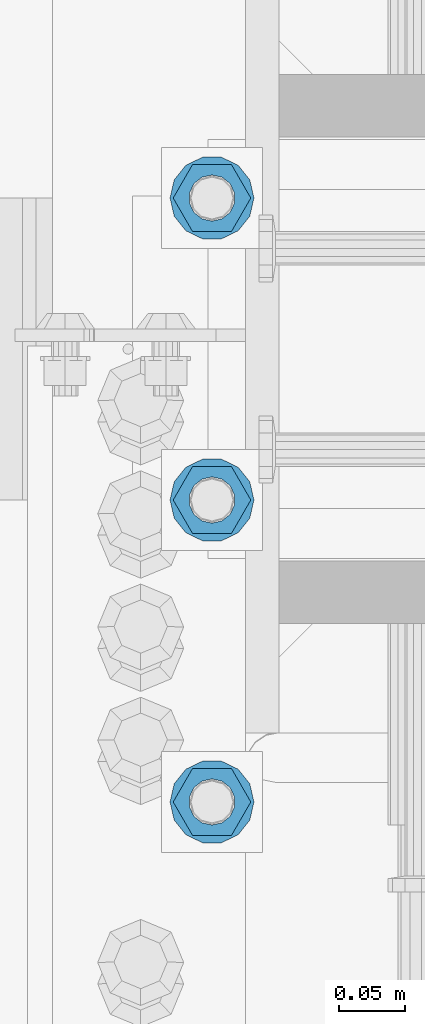
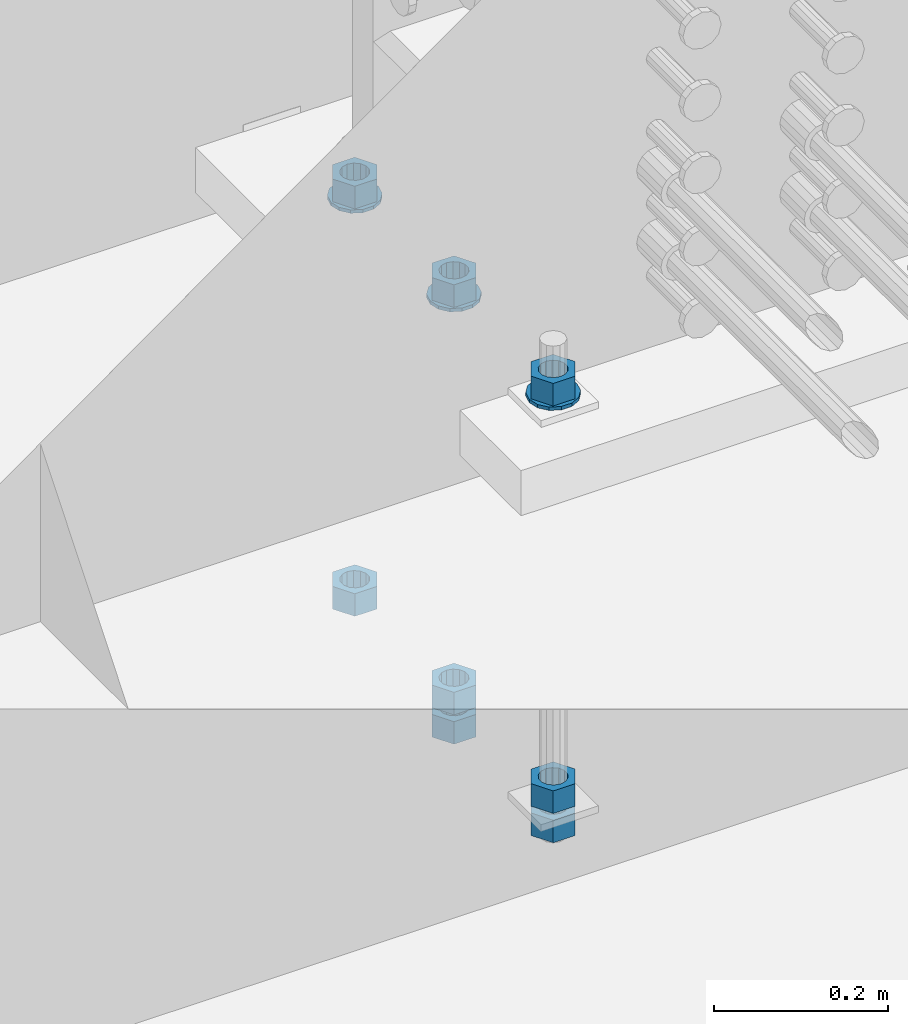
# One storey, part 1013 of 1763: 11 columns, 1 element without a shape of its own.
"""IFC2X3 building model written with IfcOpenShell, lengths in millimetres."""

from ifc_helpers import new_model, si_unit, frame, origin_with_axes, place, context, subcontext, project, spatial, faceted_brep, material, type_object, element, aggregate, save


model = new_model("IFC2X3")

# Units and contexts
model_context = context("Model", 3, precision=1e-05, world=origin_with_axes())
body_context = subcontext(model_context, "Body", "Model", "MODEL_VIEW")
ifc_project = project(units=[si_unit("LENGTHUNIT", "METRE", prefix="MILLI"), si_unit("AREAUNIT", "SQUARE_METRE"), si_unit("VOLUMEUNIT", "CUBIC_METRE"), si_unit("MASSUNIT", "GRAM", prefix="KILO"), si_unit("TIMEUNIT", "SECOND"), si_unit("PLANEANGLEUNIT", "RADIAN"), si_unit("SOLIDANGLEUNIT", "STERADIAN"), si_unit("THERMODYNAMICTEMPERATUREUNIT", "DEGREE_CELSIUS"), si_unit("LUMINOUSINTENSITYUNIT", "LUMEN")], contexts=[model_context])

# Site, building, storey
site_placement = place(None, origin_with_axes())
site = spatial("IfcSite", under=ifc_project, at=site_placement, CompositionType="ELEMENT")
building_placement = place(site_placement, origin_with_axes())
building = spatial("IfcBuilding", under=site, at=building_placement, Name="Undefined", CompositionType="ELEMENT")
storey_placement = place(building_placement, origin_with_axes())
storey = spatial("IfcBuildingStorey", under=building, at=storey_placement, Name="Undefined", CompositionType="ELEMENT", Elevation=0.0)

# Assembly, columns
assembly_placement = place(storey_placement, origin_with_axes())
assembly = element("IfcElementAssembly", 1, at=assembly_placement, inside=storey, Name="TEMPLATE", AssemblyPlace="NOTDEFINED", PredefinedType="RIGID_FRAME")
ifc_material_1 = material(Name="STEEL/A563")
column_type_1 = type_object("IfcColumnType", Name="1-1/4_HEAVY_HEX_NUT", PredefinedType="NOTDEFINED")
column_1_placement = place(assembly_placement, frame((-24281.8372736984, 13347.6999999999, 3957.6375), z_axis=(0.0, -1.0, 0.0), x_axis=(0.0, 0.0, -1.0)))
column_1 = element("IfcColumn", 2, at=column_1_placement, type_object=column_type_1, material=ifc_material_1, Name="NUT", ObjectType="1-1/4_HEAVY_HEX_NUT", context=body_context, shape_type="Brep", body=[
    faceted_brep([(0.0, -29.3700008392334, 0.0), (0.0, -14.6800003051758, -25.4300003051758), (31.75, -14.6800003051758, -25.4300003051758), (31.75, -29.3700008392334, 0.0), (0.0, 14.6800003051758, -25.4300003051758), (31.75, 14.6800003051758, -25.4300003051758), (0.0, 29.3700008392334, 0.0), (31.75, 29.3700008392334, 0.0), (0.0, 14.6800003051758, 25.4300003051758), (31.75, 14.6800003051758, 25.4300003051758), (0.0, -14.6800003051758, 25.4300003051758), (31.75, -14.6800003051758, 25.4300003051758), (0.0, 0.0, 17.4599990844727), (0.0, 7.57560968776022, 15.730915608714), (31.75, 7.57560968775942, 15.7309156087145), (31.75, 0.0, 17.4599990844727), (0.0, 13.6507769681037, 10.8861313696252), (31.75, 13.6507769681048, 10.8861313696314), (0.0, 17.0222404541215, 3.88521530314756), (31.75, 17.02224045412, 3.88521530315316), (0.0, 17.0222404541215, -3.88521530314756), (31.75, 17.02224045412, -3.88521530315332), (0.0, 13.6507769681037, -10.8861313696252), (31.75, 13.6507769681048, -10.8861313696316), (0.0, 7.57560968776022, -15.730915608714), (31.75, 7.57560968775942, -15.7309156087146), (0.0, 0.0, -17.4599990844727), (31.75, 0.0, -17.4599990844727), (0.0, -7.57560968776022, -15.730915608714), (31.75, -7.57560968775942, -15.7309156087145), (0.0, -13.6507769681037, -10.8861313696252), (31.75, -13.6507769681048, -10.8861313696314), (0.0, -17.0222404541215, -3.88521530314756), (31.75, -17.02224045412, -3.88521530315316), (0.0, -17.0222404541215, 3.88521530314756), (31.75, -17.02224045412, 3.88521530315332), (0.0, -13.6507769681037, 10.8861313696252), (31.75, -13.6507769681048, 10.8861313696316), (0.0, -7.57560968776022, 15.730915608714), (31.75, -7.57560968775942, 15.7309156087146)], [[[0, 1, 2, 3]], [[1, 4, 5, 2]], [[4, 6, 7, 5]], [[6, 8, 9, 7]], [[8, 10, 11, 9]], [[10, 0, 3, 11]], [[12, 13, 14, 15]], [[13, 16, 17, 14]], [[16, 18, 19, 17]], [[18, 20, 21, 19]], [[20, 22, 23, 21]], [[22, 24, 25, 23]], [[24, 26, 27, 25]], [[26, 28, 29, 27]], [[28, 30, 31, 29]], [[30, 32, 33, 31]], [[32, 34, 35, 33]], [[34, 36, 37, 35]], [[36, 38, 39, 37]], [[38, 12, 15, 39]], [[5, 7, 9, 11, 3, 2], [17, 19, 21, 23, 25, 27, 29, 31, 33, 35, 37, 39, 15, 14]], [[10, 8, 6, 4, 1, 0], [38, 36, 34, 32, 30, 28, 26, 24, 22, 20, 18, 16, 13, 12]]]),
])
column_2_placement = place(assembly_placement, frame((-24281.8372736984, 13347.6999999999, 3384.55), z_axis=(0.0, -1.0, 0.0), x_axis=(0.0, 0.0, -1.0)))
column_2 = element("IfcColumn", 3, at=column_2_placement, type_object=column_type_1, material=ifc_material_1, Name="NUT", ObjectType="1-1/4_HEAVY_HEX_NUT", context=body_context, shape_type="Brep", body=[
    faceted_brep([(0.0, -29.3700008392334, 0.0), (0.0, -14.6800003051758, -25.4300003051758), (31.75, -14.6800003051758, -25.4300003051758), (31.75, -29.3700008392334, 0.0), (0.0, 14.6800003051758, -25.4300003051758), (31.75, 14.6800003051758, -25.4300003051758), (0.0, 29.3700008392334, 0.0), (31.75, 29.3700008392334, 0.0), (0.0, 14.6800003051758, 25.4300003051758), (31.75, 14.6800003051758, 25.4300003051758), (0.0, -14.6800003051758, 25.4300003051758), (31.75, -14.6800003051758, 25.4300003051758), (0.0, 0.0, 17.4599990844727), (0.0, 7.57560968776022, 15.730915608714), (31.75, 7.57560968775942, 15.7309156087145), (31.75, 0.0, 17.4599990844727), (0.0, 13.6507769681037, 10.8861313696252), (31.75, 13.6507769681048, 10.8861313696314), (0.0, 17.0222404541215, 3.88521530314756), (31.75, 17.02224045412, 3.88521530315316), (0.0, 17.0222404541215, -3.88521530314756), (31.75, 17.02224045412, -3.88521530315332), (0.0, 13.6507769681037, -10.8861313696252), (31.75, 13.6507769681048, -10.8861313696316), (0.0, 7.57560968776022, -15.730915608714), (31.75, 7.57560968775942, -15.7309156087146), (0.0, 0.0, -17.4599990844727), (31.75, 0.0, -17.4599990844727), (0.0, -7.57560968776022, -15.730915608714), (31.75, -7.57560968775942, -15.7309156087145), (0.0, -13.6507769681037, -10.8861313696252), (31.75, -13.6507769681048, -10.8861313696314), (0.0, -17.0222404541215, -3.88521530314756), (31.75, -17.02224045412, -3.88521530315316), (0.0, -17.0222404541215, 3.88521530314756), (31.75, -17.02224045412, 3.88521530315332), (0.0, -13.6507769681037, 10.8861313696252), (31.75, -13.6507769681048, 10.8861313696316), (0.0, -7.57560968776022, 15.730915608714), (31.75, -7.57560968775942, 15.7309156087146)], [[[0, 1, 2, 3]], [[1, 4, 5, 2]], [[4, 6, 7, 5]], [[6, 8, 9, 7]], [[8, 10, 11, 9]], [[10, 0, 3, 11]], [[12, 13, 14, 15]], [[13, 16, 17, 14]], [[16, 18, 19, 17]], [[18, 20, 21, 19]], [[20, 22, 23, 21]], [[22, 24, 25, 23]], [[24, 26, 27, 25]], [[26, 28, 29, 27]], [[28, 30, 31, 29]], [[30, 32, 33, 31]], [[32, 34, 35, 33]], [[34, 36, 37, 35]], [[36, 38, 39, 37]], [[38, 12, 15, 39]], [[5, 7, 9, 11, 3, 2], [17, 19, 21, 23, 25, 27, 29, 31, 33, 35, 37, 39, 15, 14]], [[10, 8, 6, 4, 1, 0], [38, 36, 34, 32, 30, 28, 26, 24, 22, 20, 18, 16, 13, 12]]]),
])
column_3_placement = place(assembly_placement, frame((-24281.8372736984, 13347.6999999999, 3343.275), z_axis=(0.0, -1.0, 0.0), x_axis=(0.0, 0.0, -1.0)))
column_3 = element("IfcColumn", 4, at=column_3_placement, type_object=column_type_1, material=ifc_material_1, Name="NUT", ObjectType="1-1/4_HEAVY_HEX_NUT", context=body_context, shape_type="Brep", body=[
    faceted_brep([(0.0, -29.3700008392334, 0.0), (0.0, -14.6800003051758, -25.4300003051758), (31.75, -14.6800003051758, -25.4300003051758), (31.75, -29.3700008392334, 0.0), (0.0, 14.6800003051758, -25.4300003051758), (31.75, 14.6800003051758, -25.4300003051758), (0.0, 29.3700008392334, 0.0), (31.75, 29.3700008392334, 0.0), (0.0, 14.6800003051758, 25.4300003051758), (31.75, 14.6800003051758, 25.4300003051758), (0.0, -14.6800003051758, 25.4300003051758), (31.75, -14.6800003051758, 25.4300003051758), (0.0, 0.0, 17.4599990844727), (0.0, 7.57560968776022, 15.730915608714), (31.75, 7.57560968775942, 15.7309156087145), (31.75, 0.0, 17.4599990844727), (0.0, 13.6507769681037, 10.8861313696252), (31.75, 13.6507769681048, 10.8861313696314), (0.0, 17.0222404541215, 3.88521530314756), (31.75, 17.02224045412, 3.88521530315316), (0.0, 17.0222404541215, -3.88521530314756), (31.75, 17.02224045412, -3.88521530315332), (0.0, 13.6507769681037, -10.8861313696252), (31.75, 13.6507769681048, -10.8861313696316), (0.0, 7.57560968776022, -15.730915608714), (31.75, 7.57560968775942, -15.7309156087146), (0.0, 0.0, -17.4599990844727), (31.75, 0.0, -17.4599990844727), (0.0, -7.57560968776022, -15.730915608714), (31.75, -7.57560968775942, -15.7309156087145), (0.0, -13.6507769681037, -10.8861313696252), (31.75, -13.6507769681048, -10.8861313696314), (0.0, -17.0222404541215, -3.88521530314756), (31.75, -17.02224045412, -3.88521530315316), (0.0, -17.0222404541215, 3.88521530314756), (31.75, -17.02224045412, 3.88521530315332), (0.0, -13.6507769681037, 10.8861313696252), (31.75, -13.6507769681048, 10.8861313696316), (0.0, -7.57560968776022, 15.730915608714), (31.75, -7.57560968775942, 15.7309156087146)], [[[0, 1, 2, 3]], [[1, 4, 5, 2]], [[4, 6, 7, 5]], [[6, 8, 9, 7]], [[8, 10, 11, 9]], [[10, 0, 3, 11]], [[12, 13, 14, 15]], [[13, 16, 17, 14]], [[16, 18, 19, 17]], [[18, 20, 21, 19]], [[20, 22, 23, 21]], [[22, 24, 25, 23]], [[24, 26, 27, 25]], [[26, 28, 29, 27]], [[28, 30, 31, 29]], [[30, 32, 33, 31]], [[32, 34, 35, 33]], [[34, 36, 37, 35]], [[36, 38, 39, 37]], [[38, 12, 15, 39]], [[5, 7, 9, 11, 3, 2], [17, 19, 21, 23, 25, 27, 29, 31, 33, 35, 37, 39, 15, 14]], [[10, 8, 6, 4, 1, 0], [38, 36, 34, 32, 30, 28, 26, 24, 22, 20, 18, 16, 13, 12]]]),
])
column_4_placement = place(assembly_placement, frame((-24281.8372736984, 13576.2999999999, 3957.6375), z_axis=(0.0, -1.0, 0.0), x_axis=(0.0, 0.0, -1.0)))
column_4 = element("IfcColumn", 5, at=column_4_placement, type_object=column_type_1, material=ifc_material_1, Name="NUT", ObjectType="1-1/4_HEAVY_HEX_NUT", context=body_context, shape_type="Brep", body=[
    faceted_brep([(0.0, -29.3700008392334, 0.0), (0.0, -14.6800003051758, -25.4300003051758), (31.75, -14.6800003051758, -25.4300003051758), (31.75, -29.3700008392334, 0.0), (0.0, 14.6800003051758, -25.4300003051758), (31.75, 14.6800003051758, -25.4300003051758), (0.0, 29.3700008392334, 0.0), (31.75, 29.3700008392334, 0.0), (0.0, 14.6800003051758, 25.4300003051758), (31.75, 14.6800003051758, 25.4300003051758), (0.0, -14.6800003051758, 25.4300003051758), (31.75, -14.6800003051758, 25.4300003051758), (0.0, 0.0, 17.4599990844727), (0.0, 7.57560968776022, 15.730915608714), (31.75, 7.57560968775942, 15.7309156087145), (31.75, 0.0, 17.4599990844727), (0.0, 13.6507769681037, 10.8861313696252), (31.75, 13.6507769681048, 10.8861313696314), (0.0, 17.0222404541215, 3.88521530314756), (31.75, 17.02224045412, 3.88521530315316), (0.0, 17.0222404541215, -3.88521530314756), (31.75, 17.02224045412, -3.88521530315332), (0.0, 13.6507769681037, -10.8861313696252), (31.75, 13.6507769681048, -10.8861313696316), (0.0, 7.57560968776022, -15.730915608714), (31.75, 7.57560968775942, -15.7309156087146), (0.0, 0.0, -17.4599990844727), (31.75, 0.0, -17.4599990844727), (0.0, -7.57560968776022, -15.730915608714), (31.75, -7.57560968775942, -15.7309156087145), (0.0, -13.6507769681037, -10.8861313696252), (31.75, -13.6507769681048, -10.8861313696314), (0.0, -17.0222404541215, -3.88521530314756), (31.75, -17.02224045412, -3.88521530315316), (0.0, -17.0222404541215, 3.88521530314756), (31.75, -17.02224045412, 3.88521530315332), (0.0, -13.6507769681037, 10.8861313696252), (31.75, -13.6507769681048, 10.8861313696316), (0.0, -7.57560968776022, 15.730915608714), (31.75, -7.57560968775942, 15.7309156087146)], [[[0, 1, 2, 3]], [[1, 4, 5, 2]], [[4, 6, 7, 5]], [[6, 8, 9, 7]], [[8, 10, 11, 9]], [[10, 0, 3, 11]], [[12, 13, 14, 15]], [[13, 16, 17, 14]], [[16, 18, 19, 17]], [[18, 20, 21, 19]], [[20, 22, 23, 21]], [[22, 24, 25, 23]], [[24, 26, 27, 25]], [[26, 28, 29, 27]], [[28, 30, 31, 29]], [[30, 32, 33, 31]], [[32, 34, 35, 33]], [[34, 36, 37, 35]], [[36, 38, 39, 37]], [[38, 12, 15, 39]], [[5, 7, 9, 11, 3, 2], [17, 19, 21, 23, 25, 27, 29, 31, 33, 35, 37, 39, 15, 14]], [[10, 8, 6, 4, 1, 0], [38, 36, 34, 32, 30, 28, 26, 24, 22, 20, 18, 16, 13, 12]]]),
])
column_5_placement = place(assembly_placement, frame((-24281.8372736984, 13576.2999999999, 3384.55), z_axis=(0.0, -1.0, 0.0), x_axis=(0.0, 0.0, -1.0)))
column_5 = element("IfcColumn", 6, at=column_5_placement, type_object=column_type_1, material=ifc_material_1, Name="NUT", ObjectType="1-1/4_HEAVY_HEX_NUT", context=body_context, shape_type="Brep", body=[
    faceted_brep([(0.0, -29.3700008392334, 0.0), (0.0, -14.6800003051758, -25.4300003051758), (31.75, -14.6800003051758, -25.4300003051758), (31.75, -29.3700008392334, 0.0), (0.0, 14.6800003051758, -25.4300003051758), (31.75, 14.6800003051758, -25.4300003051758), (0.0, 29.3700008392334, 0.0), (31.75, 29.3700008392334, 0.0), (0.0, 14.6800003051758, 25.4300003051758), (31.75, 14.6800003051758, 25.4300003051758), (0.0, -14.6800003051758, 25.4300003051758), (31.75, -14.6800003051758, 25.4300003051758), (0.0, 0.0, 17.4599990844727), (0.0, 7.57560968776022, 15.730915608714), (31.75, 7.57560968775942, 15.7309156087145), (31.75, 0.0, 17.4599990844727), (0.0, 13.6507769681037, 10.8861313696252), (31.75, 13.6507769681048, 10.8861313696314), (0.0, 17.0222404541215, 3.88521530314756), (31.75, 17.02224045412, 3.88521530315316), (0.0, 17.0222404541215, -3.88521530314756), (31.75, 17.02224045412, -3.88521530315332), (0.0, 13.6507769681037, -10.8861313696252), (31.75, 13.6507769681048, -10.8861313696316), (0.0, 7.57560968776022, -15.730915608714), (31.75, 7.57560968775942, -15.7309156087146), (0.0, 0.0, -17.4599990844727), (31.75, 0.0, -17.4599990844727), (0.0, -7.57560968776022, -15.730915608714), (31.75, -7.57560968775942, -15.7309156087145), (0.0, -13.6507769681037, -10.8861313696252), (31.75, -13.6507769681048, -10.8861313696314), (0.0, -17.0222404541215, -3.88521530314756), (31.75, -17.02224045412, -3.88521530315316), (0.0, -17.0222404541215, 3.88521530314756), (31.75, -17.02224045412, 3.88521530315332), (0.0, -13.6507769681037, 10.8861313696252), (31.75, -13.6507769681048, 10.8861313696316), (0.0, -7.57560968776022, 15.730915608714), (31.75, -7.57560968775942, 15.7309156087146)], [[[0, 1, 2, 3]], [[1, 4, 5, 2]], [[4, 6, 7, 5]], [[6, 8, 9, 7]], [[8, 10, 11, 9]], [[10, 0, 3, 11]], [[12, 13, 14, 15]], [[13, 16, 17, 14]], [[16, 18, 19, 17]], [[18, 20, 21, 19]], [[20, 22, 23, 21]], [[22, 24, 25, 23]], [[24, 26, 27, 25]], [[26, 28, 29, 27]], [[28, 30, 31, 29]], [[30, 32, 33, 31]], [[32, 34, 35, 33]], [[34, 36, 37, 35]], [[36, 38, 39, 37]], [[38, 12, 15, 39]], [[5, 7, 9, 11, 3, 2], [17, 19, 21, 23, 25, 27, 29, 31, 33, 35, 37, 39, 15, 14]], [[10, 8, 6, 4, 1, 0], [38, 36, 34, 32, 30, 28, 26, 24, 22, 20, 18, 16, 13, 12]]]),
])
column_6_placement = place(assembly_placement, frame((-24281.8372736984, 13576.2999999999, 3343.275), z_axis=(0.0, -1.0, 0.0), x_axis=(0.0, 0.0, -1.0)))
column_6 = element("IfcColumn", 7, at=column_6_placement, type_object=column_type_1, material=ifc_material_1, Name="NUT", ObjectType="1-1/4_HEAVY_HEX_NUT", context=body_context, shape_type="Brep", body=[
    faceted_brep([(0.0, -29.3700008392334, 0.0), (0.0, -14.6800003051758, -25.4300003051758), (31.75, -14.6800003051758, -25.4300003051758), (31.75, -29.3700008392334, 0.0), (0.0, 14.6800003051758, -25.4300003051758), (31.75, 14.6800003051758, -25.4300003051758), (0.0, 29.3700008392334, 0.0), (31.75, 29.3700008392334, 0.0), (0.0, 14.6800003051758, 25.4300003051758), (31.75, 14.6800003051758, 25.4300003051758), (0.0, -14.6800003051758, 25.4300003051758), (31.75, -14.6800003051758, 25.4300003051758), (0.0, 0.0, 17.4599990844727), (0.0, 7.57560968776022, 15.730915608714), (31.75, 7.57560968775942, 15.7309156087145), (31.75, 0.0, 17.4599990844727), (0.0, 13.6507769681037, 10.8861313696252), (31.75, 13.6507769681048, 10.8861313696314), (0.0, 17.0222404541215, 3.88521530314756), (31.75, 17.02224045412, 3.88521530315316), (0.0, 17.0222404541215, -3.88521530314756), (31.75, 17.02224045412, -3.88521530315332), (0.0, 13.6507769681037, -10.8861313696252), (31.75, 13.6507769681048, -10.8861313696316), (0.0, 7.57560968776022, -15.730915608714), (31.75, 7.57560968775942, -15.7309156087146), (0.0, 0.0, -17.4599990844727), (31.75, 0.0, -17.4599990844727), (0.0, -7.57560968776022, -15.730915608714), (31.75, -7.57560968775942, -15.7309156087145), (0.0, -13.6507769681037, -10.8861313696252), (31.75, -13.6507769681048, -10.8861313696314), (0.0, -17.0222404541215, -3.88521530314756), (31.75, -17.02224045412, -3.88521530315316), (0.0, -17.0222404541215, 3.88521530314756), (31.75, -17.02224045412, 3.88521530315332), (0.0, -13.6507769681037, 10.8861313696252), (31.75, -13.6507769681048, 10.8861313696316), (0.0, -7.57560968776022, 15.730915608714), (31.75, -7.57560968775942, 15.7309156087146)], [[[0, 1, 2, 3]], [[1, 4, 5, 2]], [[4, 6, 7, 5]], [[6, 8, 9, 7]], [[8, 10, 11, 9]], [[10, 0, 3, 11]], [[12, 13, 14, 15]], [[13, 16, 17, 14]], [[16, 18, 19, 17]], [[18, 20, 21, 19]], [[20, 22, 23, 21]], [[22, 24, 25, 23]], [[24, 26, 27, 25]], [[26, 28, 29, 27]], [[28, 30, 31, 29]], [[30, 32, 33, 31]], [[32, 34, 35, 33]], [[34, 36, 37, 35]], [[36, 38, 39, 37]], [[38, 12, 15, 39]], [[5, 7, 9, 11, 3, 2], [17, 19, 21, 23, 25, 27, 29, 31, 33, 35, 37, 39, 15, 14]], [[10, 8, 6, 4, 1, 0], [38, 36, 34, 32, 30, 28, 26, 24, 22, 20, 18, 16, 13, 12]]]),
])
column_7_placement = place(assembly_placement, frame((-24281.8372736984, 13804.8999999999, 3957.6375), z_axis=(0.0, -1.0, 0.0), x_axis=(0.0, 0.0, -1.0)))
column_7 = element("IfcColumn", 8, at=column_7_placement, type_object=column_type_1, material=ifc_material_1, Name="NUT", ObjectType="1-1/4_HEAVY_HEX_NUT", context=body_context, shape_type="Brep", body=[
    faceted_brep([(0.0, -29.3700008392334, 0.0), (0.0, -14.6800003051758, -25.4300003051758), (31.75, -14.6800003051758, -25.4300003051758), (31.75, -29.3700008392334, 0.0), (0.0, 14.6800003051758, -25.4300003051758), (31.75, 14.6800003051758, -25.4300003051758), (0.0, 29.3700008392334, 0.0), (31.75, 29.3700008392334, 0.0), (0.0, 14.6800003051758, 25.4300003051758), (31.75, 14.6800003051758, 25.4300003051758), (0.0, -14.6800003051758, 25.4300003051758), (31.75, -14.6800003051758, 25.4300003051758), (0.0, 0.0, 17.4599990844727), (0.0, 7.57560968776022, 15.730915608714), (31.75, 7.57560968775942, 15.7309156087145), (31.75, 0.0, 17.4599990844727), (0.0, 13.6507769681037, 10.8861313696252), (31.75, 13.6507769681048, 10.8861313696314), (0.0, 17.0222404541215, 3.88521530314756), (31.75, 17.02224045412, 3.88521530315316), (0.0, 17.0222404541215, -3.88521530314756), (31.75, 17.02224045412, -3.88521530315332), (0.0, 13.6507769681037, -10.8861313696252), (31.75, 13.6507769681048, -10.8861313696316), (0.0, 7.57560968776022, -15.730915608714), (31.75, 7.57560968775942, -15.7309156087146), (0.0, 0.0, -17.4599990844727), (31.75, 0.0, -17.4599990844727), (0.0, -7.57560968776022, -15.730915608714), (31.75, -7.57560968775942, -15.7309156087145), (0.0, -13.6507769681037, -10.8861313696252), (31.75, -13.6507769681048, -10.8861313696314), (0.0, -17.0222404541215, -3.88521530314756), (31.75, -17.02224045412, -3.88521530315316), (0.0, -17.0222404541215, 3.88521530314756), (31.75, -17.02224045412, 3.88521530315332), (0.0, -13.6507769681037, 10.8861313696252), (31.75, -13.6507769681048, 10.8861313696316), (0.0, -7.57560968776022, 15.730915608714), (31.75, -7.57560968775942, 15.7309156087146)], [[[0, 1, 2, 3]], [[1, 4, 5, 2]], [[4, 6, 7, 5]], [[6, 8, 9, 7]], [[8, 10, 11, 9]], [[10, 0, 3, 11]], [[12, 13, 14, 15]], [[13, 16, 17, 14]], [[16, 18, 19, 17]], [[18, 20, 21, 19]], [[20, 22, 23, 21]], [[22, 24, 25, 23]], [[24, 26, 27, 25]], [[26, 28, 29, 27]], [[28, 30, 31, 29]], [[30, 32, 33, 31]], [[32, 34, 35, 33]], [[34, 36, 37, 35]], [[36, 38, 39, 37]], [[38, 12, 15, 39]], [[5, 7, 9, 11, 3, 2], [17, 19, 21, 23, 25, 27, 29, 31, 33, 35, 37, 39, 15, 14]], [[10, 8, 6, 4, 1, 0], [38, 36, 34, 32, 30, 28, 26, 24, 22, 20, 18, 16, 13, 12]]]),
])
column_8_placement = place(assembly_placement, frame((-24281.8372736984, 13804.8999999999, 3384.55), z_axis=(0.0, -1.0, 0.0), x_axis=(0.0, 0.0, -1.0)))
column_8 = element("IfcColumn", 9, at=column_8_placement, type_object=column_type_1, material=ifc_material_1, Name="NUT", ObjectType="1-1/4_HEAVY_HEX_NUT", context=body_context, shape_type="Brep", body=[
    faceted_brep([(0.0, -29.3700008392334, 0.0), (0.0, -14.6800003051758, -25.4300003051758), (31.75, -14.6800003051758, -25.4300003051758), (31.75, -29.3700008392334, 0.0), (0.0, 14.6800003051758, -25.4300003051758), (31.75, 14.6800003051758, -25.4300003051758), (0.0, 29.3700008392334, 0.0), (31.75, 29.3700008392334, 0.0), (0.0, 14.6800003051758, 25.4300003051758), (31.75, 14.6800003051758, 25.4300003051758), (0.0, -14.6800003051758, 25.4300003051758), (31.75, -14.6800003051758, 25.4300003051758), (0.0, 0.0, 17.4599990844727), (0.0, 7.57560968776022, 15.730915608714), (31.75, 7.57560968775942, 15.7309156087145), (31.75, 0.0, 17.4599990844727), (0.0, 13.6507769681037, 10.8861313696252), (31.75, 13.6507769681048, 10.8861313696314), (0.0, 17.0222404541215, 3.88521530314756), (31.75, 17.02224045412, 3.88521530315316), (0.0, 17.0222404541215, -3.88521530314756), (31.75, 17.02224045412, -3.88521530315332), (0.0, 13.6507769681037, -10.8861313696252), (31.75, 13.6507769681048, -10.8861313696316), (0.0, 7.57560968776022, -15.730915608714), (31.75, 7.57560968775942, -15.7309156087146), (0.0, 0.0, -17.4599990844727), (31.75, 0.0, -17.4599990844727), (0.0, -7.57560968776022, -15.730915608714), (31.75, -7.57560968775942, -15.7309156087145), (0.0, -13.6507769681037, -10.8861313696252), (31.75, -13.6507769681048, -10.8861313696314), (0.0, -17.0222404541215, -3.88521530314756), (31.75, -17.02224045412, -3.88521530315316), (0.0, -17.0222404541215, 3.88521530314756), (31.75, -17.02224045412, 3.88521530315332), (0.0, -13.6507769681037, 10.8861313696252), (31.75, -13.6507769681048, 10.8861313696316), (0.0, -7.57560968776022, 15.730915608714), (31.75, -7.57560968775942, 15.7309156087146)], [[[0, 1, 2, 3]], [[1, 4, 5, 2]], [[4, 6, 7, 5]], [[6, 8, 9, 7]], [[8, 10, 11, 9]], [[10, 0, 3, 11]], [[12, 13, 14, 15]], [[13, 16, 17, 14]], [[16, 18, 19, 17]], [[18, 20, 21, 19]], [[20, 22, 23, 21]], [[22, 24, 25, 23]], [[24, 26, 27, 25]], [[26, 28, 29, 27]], [[28, 30, 31, 29]], [[30, 32, 33, 31]], [[32, 34, 35, 33]], [[34, 36, 37, 35]], [[36, 38, 39, 37]], [[38, 12, 15, 39]], [[5, 7, 9, 11, 3, 2], [17, 19, 21, 23, 25, 27, 29, 31, 33, 35, 37, 39, 15, 14]], [[10, 8, 6, 4, 1, 0], [38, 36, 34, 32, 30, 28, 26, 24, 22, 20, 18, 16, 13, 12]]]),
])
ifc_material_2 = material(Name="STEEL/F436")
column_type_2 = type_object("IfcColumnType", Name="1-1/4_WASHER", PredefinedType="NOTDEFINED")
column_9_placement = place(assembly_placement, frame((-24281.8372736984, 13347.6999999999, 3925.8875), z_axis=(0.0, -1.0, 0.0), x_axis=(0.0, 0.0, -1.0)))
column_9 = element("IfcColumn", 10, at=column_9_placement, type_object=column_type_2, material=ifc_material_2, Name="WASHER", ObjectType="1-1/4_WASHER", context=body_context, shape_type="Brep", body=[
    faceted_brep([(-4.54747350886464e-13, -31.7499999999964, 0.0), (0.0, -28.6057615559002, -13.7758087169827), (4.76249999999982, -28.6057615559002, -13.7758087169827), (4.76249999999982, -31.75, 0.0), (0.0, -19.795801209013, -24.8231495683602), (4.76249999999982, -19.795801209013, -24.8231495683602), (0.0, -7.06503965311276, -30.9539612117732), (4.76249999999982, -7.06503965311276, -30.9539612117732), (0.0, 7.06503965311276, -30.9539612117732), (4.76249999999982, 7.06503965311276, -30.9539612117732), (0.0, 19.7958012090166, -24.8231495683602), (4.76249999999982, 19.7958012090166, -24.8231495683602), (0.0, 28.6057615559039, -13.7758087169827), (4.76249999999982, 28.6057615559039, -13.7758087169827), (-5.91171556152403e-12, 31.7499999999891, 0.0), (4.76249999999982, 31.75, 0.0), (0.0, 28.6057615559002, 13.7758087169827), (4.76249999999982, 28.6057615559002, 13.7758087169827), (0.0, 19.795801209013, 24.8231495683602), (4.76249999999982, 19.795801209013, 24.8231495683602), (0.0, 7.06503965311276, 30.9539612117731), (4.76249999999982, 7.06503965311276, 30.9539612117731), (0.0, -7.06503965311276, 30.9539612117731), (4.76249999999982, -7.06503965311276, 30.9539612117731), (0.0, -19.7958012090166, 24.8231495683602), (4.76249999999982, -19.7958012090166, 24.8231495683602), (0.0, -28.6057615559039, 13.7758087169827), (4.76249999999982, -28.6057615559039, 13.7758087169827), (0.0, 0.0, 17.4599990844727), (0.0, 7.57560968776022, 15.730915608714), (4.76249999999982, 7.57560968775942, 15.7309156087145), (4.76249999999982, 0.0, 17.4599990844727), (0.0, 13.6507769681037, 10.8861313696252), (4.76249999999982, 13.6507769681048, 10.8861313696314), (0.0, 17.0222404541215, 3.88521530314756), (4.76249999999982, 17.02224045412, 3.88521530315316), (0.0, 17.0222404541215, -3.88521530314756), (4.76249999999982, 17.02224045412, -3.88521530315332), (0.0, 13.6507769681037, -10.8861313696252), (4.76249999999982, 13.6507769681048, -10.8861313696316), (0.0, 7.57560968776022, -15.730915608714), (4.76249999999982, 7.57560968775942, -15.7309156087146), (0.0, 0.0, -17.4599990844727), (4.76249999999982, 0.0, -17.4599990844727), (0.0, -7.57560968776022, -15.730915608714), (4.76249999999982, -7.57560968775942, -15.7309156087145), (0.0, -13.6507769681037, -10.8861313696252), (4.76249999999982, -13.6507769681048, -10.8861313696314), (0.0, -17.0222404541215, -3.88521530314756), (4.76249999999982, -17.02224045412, -3.88521530315316), (0.0, -17.0222404541215, 3.88521530314756), (4.76249999999982, -17.02224045412, 3.88521530315332), (0.0, -13.6507769681037, 10.8861313696252), (4.76249999999982, -13.6507769681048, 10.8861313696316), (0.0, -7.57560968776022, 15.730915608714), (4.76249999999982, -7.57560968775942, 15.7309156087146)], [[[0, 1, 2, 3]], [[1, 4, 5, 2]], [[4, 6, 7, 5]], [[6, 8, 9, 7]], [[8, 10, 11, 9]], [[10, 12, 13, 11]], [[12, 14, 15, 13]], [[14, 16, 17, 15]], [[16, 18, 19, 17]], [[18, 20, 21, 19]], [[20, 22, 23, 21]], [[22, 24, 25, 23]], [[24, 26, 27, 25]], [[26, 0, 3, 27]], [[28, 29, 30, 31]], [[29, 32, 33, 30]], [[32, 34, 35, 33]], [[34, 36, 37, 35]], [[36, 38, 39, 37]], [[38, 40, 41, 39]], [[40, 42, 43, 41]], [[42, 44, 45, 43]], [[44, 46, 47, 45]], [[46, 48, 49, 47]], [[48, 50, 51, 49]], [[50, 52, 53, 51]], [[52, 54, 55, 53]], [[54, 28, 31, 55]], [[5, 7, 9, 11, 13, 15, 17, 19, 21, 23, 25, 27, 3, 2], [33, 35, 37, 39, 41, 43, 45, 47, 49, 51, 53, 55, 31, 30]], [[26, 24, 22, 20, 18, 16, 14, 12, 10, 8, 6, 4, 1, 0], [54, 52, 50, 48, 46, 44, 42, 40, 38, 36, 34, 32, 29, 28]]]),
])
column_10_placement = place(assembly_placement, frame((-24281.8372736984, 13576.2999999999, 3925.8875), z_axis=(0.0, -1.0, 0.0), x_axis=(0.0, 0.0, -1.0)))
column_10 = element("IfcColumn", 11, at=column_10_placement, type_object=column_type_2, material=ifc_material_2, Name="WASHER", ObjectType="1-1/4_WASHER", context=body_context, shape_type="Brep", body=[
    faceted_brep([(-4.54747350886464e-13, -31.7499999999964, 0.0), (0.0, -28.6057615559002, -13.7758087169827), (4.76249999999982, -28.6057615559002, -13.7758087169827), (4.76249999999982, -31.75, 0.0), (0.0, -19.795801209013, -24.8231495683602), (4.76249999999982, -19.795801209013, -24.8231495683602), (0.0, -7.06503965311276, -30.9539612117732), (4.76249999999982, -7.06503965311276, -30.9539612117732), (0.0, 7.06503965311276, -30.9539612117732), (4.76249999999982, 7.06503965311276, -30.9539612117732), (0.0, 19.7958012090166, -24.8231495683602), (4.76249999999982, 19.7958012090166, -24.8231495683602), (0.0, 28.6057615559039, -13.7758087169827), (4.76249999999982, 28.6057615559039, -13.7758087169827), (-5.91171556152403e-12, 31.7499999999891, 0.0), (4.76249999999982, 31.75, 0.0), (0.0, 28.6057615559002, 13.7758087169827), (4.76249999999982, 28.6057615559002, 13.7758087169827), (0.0, 19.795801209013, 24.8231495683602), (4.76249999999982, 19.795801209013, 24.8231495683602), (0.0, 7.06503965311276, 30.9539612117731), (4.76249999999982, 7.06503965311276, 30.9539612117731), (0.0, -7.06503965311276, 30.9539612117731), (4.76249999999982, -7.06503965311276, 30.9539612117731), (0.0, -19.7958012090166, 24.8231495683602), (4.76249999999982, -19.7958012090166, 24.8231495683602), (0.0, -28.6057615559039, 13.7758087169827), (4.76249999999982, -28.6057615559039, 13.7758087169827), (0.0, 0.0, 17.4599990844727), (0.0, 7.57560968776022, 15.730915608714), (4.76249999999982, 7.57560968775942, 15.7309156087145), (4.76249999999982, 0.0, 17.4599990844727), (0.0, 13.6507769681037, 10.8861313696252), (4.76249999999982, 13.6507769681048, 10.8861313696314), (0.0, 17.0222404541215, 3.88521530314756), (4.76249999999982, 17.02224045412, 3.88521530315316), (0.0, 17.0222404541215, -3.88521530314756), (4.76249999999982, 17.02224045412, -3.88521530315332), (0.0, 13.6507769681037, -10.8861313696252), (4.76249999999982, 13.6507769681048, -10.8861313696316), (0.0, 7.57560968776022, -15.730915608714), (4.76249999999982, 7.57560968775942, -15.7309156087146), (0.0, 0.0, -17.4599990844727), (4.76249999999982, 0.0, -17.4599990844727), (0.0, -7.57560968776022, -15.730915608714), (4.76249999999982, -7.57560968775942, -15.7309156087145), (0.0, -13.6507769681037, -10.8861313696252), (4.76249999999982, -13.6507769681048, -10.8861313696314), (0.0, -17.0222404541215, -3.88521530314756), (4.76249999999982, -17.02224045412, -3.88521530315316), (0.0, -17.0222404541215, 3.88521530314756), (4.76249999999982, -17.02224045412, 3.88521530315332), (0.0, -13.6507769681037, 10.8861313696252), (4.76249999999982, -13.6507769681048, 10.8861313696316), (0.0, -7.57560968776022, 15.730915608714), (4.76249999999982, -7.57560968775942, 15.7309156087146)], [[[0, 1, 2, 3]], [[1, 4, 5, 2]], [[4, 6, 7, 5]], [[6, 8, 9, 7]], [[8, 10, 11, 9]], [[10, 12, 13, 11]], [[12, 14, 15, 13]], [[14, 16, 17, 15]], [[16, 18, 19, 17]], [[18, 20, 21, 19]], [[20, 22, 23, 21]], [[22, 24, 25, 23]], [[24, 26, 27, 25]], [[26, 0, 3, 27]], [[28, 29, 30, 31]], [[29, 32, 33, 30]], [[32, 34, 35, 33]], [[34, 36, 37, 35]], [[36, 38, 39, 37]], [[38, 40, 41, 39]], [[40, 42, 43, 41]], [[42, 44, 45, 43]], [[44, 46, 47, 45]], [[46, 48, 49, 47]], [[48, 50, 51, 49]], [[50, 52, 53, 51]], [[52, 54, 55, 53]], [[54, 28, 31, 55]], [[5, 7, 9, 11, 13, 15, 17, 19, 21, 23, 25, 27, 3, 2], [33, 35, 37, 39, 41, 43, 45, 47, 49, 51, 53, 55, 31, 30]], [[26, 24, 22, 20, 18, 16, 14, 12, 10, 8, 6, 4, 1, 0], [54, 52, 50, 48, 46, 44, 42, 40, 38, 36, 34, 32, 29, 28]]]),
])
column_11_placement = place(assembly_placement, frame((-24281.8372736984, 13804.8999999999, 3925.8875), z_axis=(0.0, -1.0, 0.0), x_axis=(0.0, 0.0, -1.0)))
column_11 = element("IfcColumn", 12, at=column_11_placement, type_object=column_type_2, material=ifc_material_2, Name="WASHER", ObjectType="1-1/4_WASHER", context=body_context, shape_type="Brep", body=[
    faceted_brep([(-4.54747350886464e-13, -31.7499999999964, 0.0), (0.0, -28.6057615559002, -13.7758087169827), (4.76249999999982, -28.6057615559002, -13.7758087169827), (4.76249999999982, -31.75, 0.0), (0.0, -19.795801209013, -24.8231495683602), (4.76249999999982, -19.795801209013, -24.8231495683602), (0.0, -7.06503965311276, -30.9539612117732), (4.76249999999982, -7.06503965311276, -30.9539612117732), (0.0, 7.06503965311276, -30.9539612117732), (4.76249999999982, 7.06503965311276, -30.9539612117732), (0.0, 19.7958012090166, -24.8231495683602), (4.76249999999982, 19.7958012090166, -24.8231495683602), (0.0, 28.6057615559039, -13.7758087169827), (4.76249999999982, 28.6057615559039, -13.7758087169827), (-5.91171556152403e-12, 31.7499999999891, 0.0), (4.76249999999982, 31.75, 0.0), (0.0, 28.6057615559002, 13.7758087169827), (4.76249999999982, 28.6057615559002, 13.7758087169827), (0.0, 19.795801209013, 24.8231495683602), (4.76249999999982, 19.795801209013, 24.8231495683602), (0.0, 7.06503965311276, 30.9539612117731), (4.76249999999982, 7.06503965311276, 30.9539612117731), (0.0, -7.06503965311276, 30.9539612117731), (4.76249999999982, -7.06503965311276, 30.9539612117731), (0.0, -19.7958012090166, 24.8231495683602), (4.76249999999982, -19.7958012090166, 24.8231495683602), (0.0, -28.6057615559039, 13.7758087169827), (4.76249999999982, -28.6057615559039, 13.7758087169827), (0.0, 0.0, 17.4599990844727), (0.0, 7.57560968776022, 15.730915608714), (4.76249999999982, 7.57560968775942, 15.7309156087145), (4.76249999999982, 0.0, 17.4599990844727), (0.0, 13.6507769681037, 10.8861313696252), (4.76249999999982, 13.6507769681048, 10.8861313696314), (0.0, 17.0222404541215, 3.88521530314756), (4.76249999999982, 17.02224045412, 3.88521530315316), (0.0, 17.0222404541215, -3.88521530314756), (4.76249999999982, 17.02224045412, -3.88521530315332), (0.0, 13.6507769681037, -10.8861313696252), (4.76249999999982, 13.6507769681048, -10.8861313696316), (0.0, 7.57560968776022, -15.730915608714), (4.76249999999982, 7.57560968775942, -15.7309156087146), (0.0, 0.0, -17.4599990844727), (4.76249999999982, 0.0, -17.4599990844727), (0.0, -7.57560968776022, -15.730915608714), (4.76249999999982, -7.57560968775942, -15.7309156087145), (0.0, -13.6507769681037, -10.8861313696252), (4.76249999999982, -13.6507769681048, -10.8861313696314), (0.0, -17.0222404541215, -3.88521530314756), (4.76249999999982, -17.02224045412, -3.88521530315316), (0.0, -17.0222404541215, 3.88521530314756), (4.76249999999982, -17.02224045412, 3.88521530315332), (0.0, -13.6507769681037, 10.8861313696252), (4.76249999999982, -13.6507769681048, 10.8861313696316), (0.0, -7.57560968776022, 15.730915608714), (4.76249999999982, -7.57560968775942, 15.7309156087146)], [[[0, 1, 2, 3]], [[1, 4, 5, 2]], [[4, 6, 7, 5]], [[6, 8, 9, 7]], [[8, 10, 11, 9]], [[10, 12, 13, 11]], [[12, 14, 15, 13]], [[14, 16, 17, 15]], [[16, 18, 19, 17]], [[18, 20, 21, 19]], [[20, 22, 23, 21]], [[22, 24, 25, 23]], [[24, 26, 27, 25]], [[26, 0, 3, 27]], [[28, 29, 30, 31]], [[29, 32, 33, 30]], [[32, 34, 35, 33]], [[34, 36, 37, 35]], [[36, 38, 39, 37]], [[38, 40, 41, 39]], [[40, 42, 43, 41]], [[42, 44, 45, 43]], [[44, 46, 47, 45]], [[46, 48, 49, 47]], [[48, 50, 51, 49]], [[50, 52, 53, 51]], [[52, 54, 55, 53]], [[54, 28, 31, 55]], [[5, 7, 9, 11, 13, 15, 17, 19, 21, 23, 25, 27, 3, 2], [33, 35, 37, 39, 41, 43, 45, 47, 49, 51, 53, 55, 31, 30]], [[26, 24, 22, 20, 18, 16, 14, 12, 10, 8, 6, 4, 1, 0], [54, 52, 50, 48, 46, 44, 42, 40, 38, 36, 34, 32, 29, 28]]]),
])
aggregate(assembly, [column_1, column_9, column_2, column_3, column_4, column_10, column_5, column_6, column_7, column_11, column_8])

save(model, "model.ifc")
